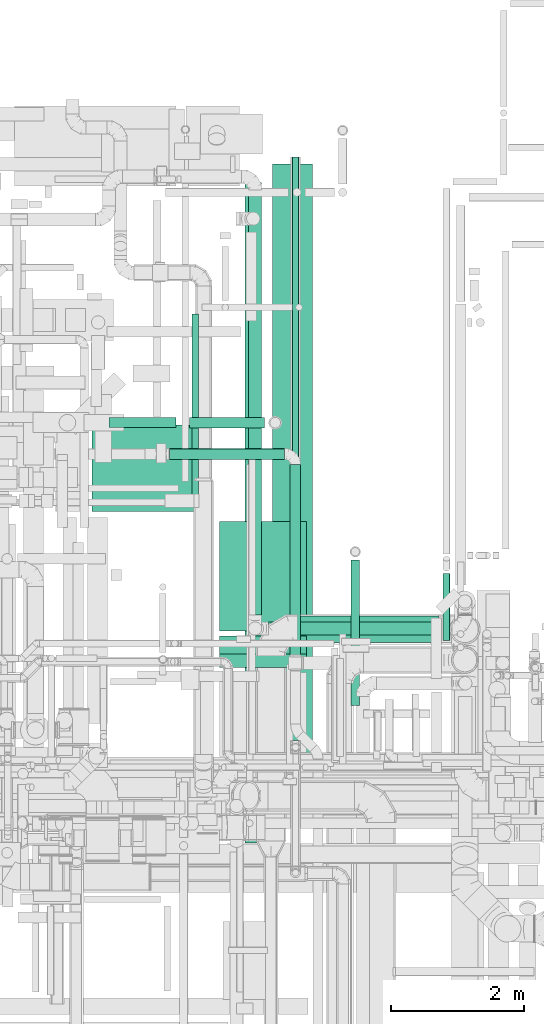
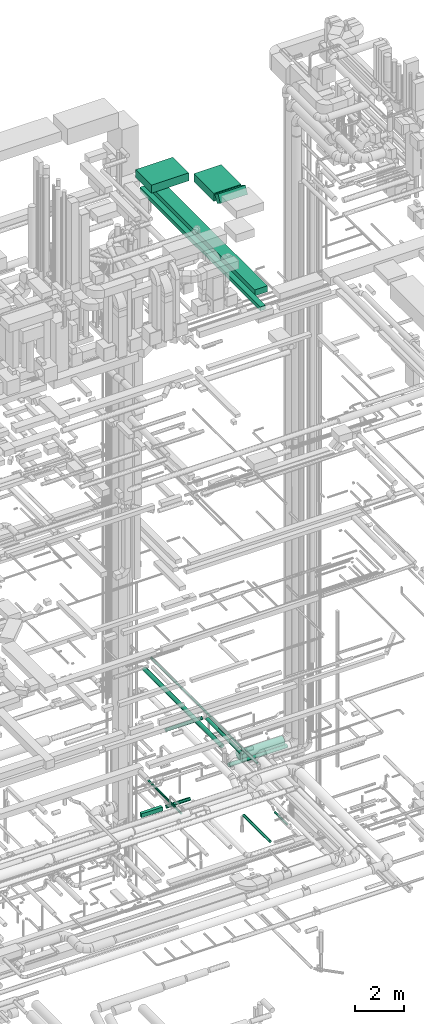
# One storey, part 69 of 337: 16 flow segments.
"""IFC2X3 building model written with IfcOpenShell, lengths in millimetres."""

from ifc_helpers import new_model, entity, si_unit, converted_unit, derived_unit, direction, frame, frame_2d, origin, origin_2d_with_axis, place, context, subcontext, project, spatial, rectangle, circle, extrude, type_object, element, save


model = new_model("IFC2X3")

# Units and contexts
model_context = context("Model", 3, precision=0.01, world=origin(), true_north=direction((6.12303176911189e-17, 1.0)))
body_context = subcontext(model_context, "Body", "Model", "MODEL_VIEW")
ifc_project = project(units=[si_unit("LENGTHUNIT", "METRE", prefix="MILLI"), si_unit("AREAUNIT", "SQUARE_METRE"), si_unit("VOLUMEUNIT", "CUBIC_METRE"), converted_unit("PLANEANGLEUNIT", "DEGREE", entity("IfcRatioMeasure", 0.0174532925199433), si_unit("PLANEANGLEUNIT", "RADIAN"), dimensions=[0, 0, 0, 0, 0, 0, 0]), si_unit("MASSUNIT", "GRAM", prefix="KILO"), derived_unit("MASSDENSITYUNIT", [(si_unit("MASSUNIT", "GRAM", prefix="KILO"), 1), (si_unit("LENGTHUNIT", "METRE"), -3)]), derived_unit("MOMENTOFINERTIAUNIT", [(si_unit("LENGTHUNIT", "METRE"), 4)]), si_unit("TIMEUNIT", "SECOND"), si_unit("FREQUENCYUNIT", "HERTZ"), si_unit("THERMODYNAMICTEMPERATUREUNIT", "DEGREE_CELSIUS"), derived_unit("THERMALTRANSMITTANCEUNIT", [(si_unit("MASSUNIT", "GRAM", prefix="KILO"), 1), (si_unit("THERMODYNAMICTEMPERATUREUNIT", "KELVIN"), -1), (si_unit("TIMEUNIT", "SECOND"), -3)]), derived_unit("VOLUMETRICFLOWRATEUNIT", [(si_unit("LENGTHUNIT", "METRE"), 3), (si_unit("TIMEUNIT", "SECOND"), -1)]), derived_unit("MASSFLOWRATEUNIT", [(si_unit("MASSUNIT", "GRAM", prefix="KILO"), 1), (si_unit("TIMEUNIT", "SECOND"), -1)]), derived_unit("ROTATIONALFREQUENCYUNIT", [(si_unit("TIMEUNIT", "SECOND"), -1)]), si_unit("ELECTRICCURRENTUNIT", "AMPERE"), si_unit("ELECTRICVOLTAGEUNIT", "VOLT"), si_unit("POWERUNIT", "WATT"), si_unit("FORCEUNIT", "NEWTON", prefix="KILO"), si_unit("ILLUMINANCEUNIT", "LUX"), si_unit("LUMINOUSFLUXUNIT", "LUMEN"), si_unit("LUMINOUSINTENSITYUNIT", "CANDELA"), derived_unit("USERDEFINED", [(si_unit("MASSUNIT", "GRAM", prefix="KILO"), -1), (si_unit("LENGTHUNIT", "METRE"), -2), (si_unit("TIMEUNIT", "SECOND"), 3), (si_unit("LUMINOUSFLUXUNIT", "LUMEN"), 1)]), derived_unit("LINEARVELOCITYUNIT", [(si_unit("LENGTHUNIT", "METRE"), 1), (si_unit("TIMEUNIT", "SECOND"), -1)]), si_unit("PRESSUREUNIT", "PASCAL"), derived_unit("USERDEFINED", [(si_unit("LENGTHUNIT", "METRE"), -2), (si_unit("MASSUNIT", "GRAM", prefix="KILO"), 1), (si_unit("TIMEUNIT", "SECOND"), -2)]), derived_unit("LINEARFORCEUNIT", [(si_unit("MASSUNIT", "GRAM", prefix="KILO"), 1), (si_unit("LENGTHUNIT", "METRE"), 1), (si_unit("TIMEUNIT", "SECOND"), -2), (si_unit("LENGTHUNIT", "METRE"), -1)]), derived_unit("PLANARFORCEUNIT", [(si_unit("MASSUNIT", "GRAM", prefix="KILO"), 1), (si_unit("LENGTHUNIT", "METRE"), 1), (si_unit("TIMEUNIT", "SECOND"), -2), (si_unit("LENGTHUNIT", "METRE"), -2)])], contexts=[model_context])

# Site, building, storey
site_placement = place(None, origin())
site = spatial("IfcSite", under=ifc_project, at=site_placement, CompositionType="ELEMENT")
building_placement = place(site_placement, origin())
building = spatial("IfcBuilding", under=site, at=building_placement, CompositionType="ELEMENT")
storey_placement = place(building_placement, origin())
storey = spatial("IfcBuildingStorey", under=building, at=storey_placement, CompositionType="ELEMENT", Elevation=0.0)

# Flow segments
duct_segment_type_1 = type_object("IfcDuctSegmentType", PredefinedType="NOTDEFINED")
flow_segment_1_placement = place(storey_placement, frame((62220.37, 15273.96, -950.0)))
element("IfcFlowSegment", 1, at=flow_segment_1_placement, inside=storey, type_object=duct_segment_type_1, context=body_context, shape_type="SweptSolid", body=[
    extrude(rectangle(XDim=1006.91276425047, YDim=150.000000000001, at=origin_2d_with_axis()), frame((503.46, 75.0, 0.0)), (0.0, 0.0, 1.0), 200.0),
])
flow_segment_2_placement = place(storey_placement, frame((64257.65, 9045.02, 27550.0)))
element("IfcFlowSegment", 2, at=flow_segment_2_placement, inside=storey, type_object=duct_segment_type_1, context=body_context, shape_type="SweptSolid", body=[
    extrude(rectangle(XDim=9908.10000000008, YDim=250.000000000004, at=origin_2d_with_axis()), frame((125.0, 4954.05, 0.0), z_axis=(0.0, 0.0, 1.0), x_axis=(0.0, 1.0, 0.0)), (0.0, 0.0, 1.0), 199.999999999998),
])
flow_segment_3_placement = place(storey_placement, frame((64670.0, 10213.98, 27450.0)))
element("IfcFlowSegment", 3, at=flow_segment_3_placement, inside=storey, type_object=duct_segment_type_1, context=body_context, shape_type="SweptSolid", body=[
    extrude(rectangle(XDim=9020.00000000004, YDim=600.000000000002, at=origin_2d_with_axis()), frame((300.0, 4510.0, 0.0), z_axis=(0.0, 0.0, 1.0), x_axis=(0.0, 1.0, 0.0)), (0.0, 0.0, 1.0), 300.000000000001),
])
duct_segment_type_2 = type_object("IfcDuctSegmentType", PredefinedType="NOTDEFINED")
flow_segment_4_placement = place(storey_placement, frame((63427.28, 15267.36, -931.6)))
element("IfcFlowSegment", 4, at=flow_segment_4_placement, inside=storey, type_object=duct_segment_type_2, context=body_context, shape_type="SweptSolid", body=[
    extrude(circle(Radius=80.0, at=origin_2d_with_axis()), frame((0.0, 81.6, 81.6), z_axis=(1.0, 0.0, 0.0), x_axis=(0.0, -1.0, 0.0)), (0.0, 0.0, 1.0), 1126.40133976584),
])
flow_segment_5_placement = place(storey_placement, frame((65849.84, 11105.22, -964.1)))
element("IfcFlowSegment", 5, at=flow_segment_5_placement, inside=storey, type_object=duct_segment_type_2, context=body_context, shape_type="SweptSolid", body=[
    extrude(circle(Radius=62.5, at=origin_2d_with_axis()), frame((64.1, 0.0, 64.1), z_axis=(0.0, 1.0, 0.0), x_axis=(1.0, 0.0, 0.0)), (0.0, 0.0, 1.0), 2182.57919999999),
])
flow_segment_6_placement = place(storey_placement, frame((67230.68, 12078.54, -1161.6)))
element("IfcFlowSegment", 6, at=flow_segment_6_placement, inside=storey, type_object=duct_segment_type_2, context=body_context, shape_type="SweptSolid", body=[
    extrude(circle(Radius=50.0, at=origin_2d_with_axis()), frame((51.6, 0.0, 51.6), z_axis=(0.0, 1.0, 0.0), x_axis=(1.0, 0.0, 0.0)), (0.0, 0.0, 1.0), 1009.4652237627),
])
flow_segment_7_placement = place(storey_placement, frame((63462.6, 14253.27, -601.6)))
element("IfcFlowSegment", 7, at=flow_segment_7_placement, inside=storey, type_object=duct_segment_type_2, context=body_context, shape_type="SweptSolid", body=[
    extrude(circle(Radius=50.0, at=origin_2d_with_axis()), frame((51.6, 0.0, 51.6), z_axis=(0.0, 1.0, 0.0), x_axis=(1.0, 0.0, 0.0)), (0.0, 0.0, 1.0), 2726.83352),
])
flow_segment_8_placement = place(storey_placement, frame((65048.27, 12048.32, 2848.4)))
element("IfcFlowSegment", 8, at=flow_segment_8_placement, inside=storey, type_object=duct_segment_type_2, context=body_context, shape_type="SweptSolid", body=[
    extrude(circle(Radius=200.0, at=origin_2d_with_axis()), frame((0.0, 201.6, 201.6), z_axis=(1.0, 0.0, 0.0), x_axis=(0.0, 1.0, 0.0)), (0.0, 0.0, 1.0), 2114.94669087573),
])
flow_segment_9_placement = place(storey_placement, frame((64965.15, 10579.14, 3598.4)))
element("IfcFlowSegment", 9, at=flow_segment_9_placement, inside=storey, type_object=duct_segment_type_2, context=body_context, shape_type="SweptSolid", body=[
    extrude(circle(Radius=50.0, at=origin_2d_with_axis()), frame((51.6, 0.0, 51.6), z_axis=(0.0, 1.0, 0.0), x_axis=(1.0, 0.0, 0.0)), (0.0, 0.0, 1.0), 8755.19859995445),
])
flow_segment_10_placement = place(storey_placement, frame((64610.14, 12159.21, 2598.4)))
element("IfcFlowSegment", 10, at=flow_segment_10_placement, inside=storey, type_object=duct_segment_type_2, context=body_context, shape_type="SweptSolid", body=[
    extrude(circle(Radius=100.0, at=origin_2d_with_axis()), frame((0.0, 101.6, 101.6), z_axis=(1.0, 0.0, 0.0), x_axis=(0.0, -1.0, 0.0)), (0.0, 0.0, 1.0), 2753.82994704765),
])
flow_segment_11_placement = place(storey_placement, frame((64932.89, 11864.28, 3298.4)))
element("IfcFlowSegment", 11, at=flow_segment_11_placement, inside=storey, type_object=duct_segment_type_2, context=body_context, shape_type="SweptSolid", body=[
    extrude(circle(Radius=80.0, at=origin_2d_with_axis()), frame((81.6, 0.0, 81.6), z_axis=(0.0, 1.0, 0.0), x_axis=(-1.0, 0.0, 0.0)), (0.0, 0.0, 1.0), 2854.45238542295),
])
flow_segment_12_placement = place(storey_placement, frame((64308.55, 12460.8, 3498.4)))
element("IfcFlowSegment", 12, at=flow_segment_12_placement, inside=storey, type_object=duct_segment_type_2, context=body_context, shape_type="SweptSolid", body=[
    extrude(circle(Radius=100.0, at=origin_2d_with_axis()), frame((101.6, 0.0, 101.6), z_axis=(0.0, 1.0, 0.0), x_axis=(1.0, 0.0, 0.0)), (0.0, 0.0, 1.0), 6380.00000000002),
])
flow_segment_13_placement = place(storey_placement, frame((63127.15, 14797.14, 3298.4)))
element("IfcFlowSegment", 13, at=flow_segment_13_placement, inside=storey, type_object=duct_segment_type_2, context=body_context, shape_type="SweptSolid", body=[
    extrude(circle(Radius=80.0, at=origin_2d_with_axis()), frame((0.0, 81.6, 81.6), z_axis=(1.0, 0.0, 0.0), x_axis=(0.0, 1.0, 0.0)), (0.0, 0.0, 1.0), 1727.34177453729),
])
duct_segment_type_3 = type_object("IfcDuctSegmentType", PredefinedType="NOTDEFINED")
flow_segment_14_placement = place(storey_placement, frame((61963.17, 14014.6, 31250.0)))
element("IfcFlowSegment", 14, at=flow_segment_14_placement, inside=storey, type_object=duct_segment_type_3, context=body_context, shape_type="SweptSolid", body=[
    extrude(rectangle(XDim=1766.81781000004, YDim=1300.0, at=origin_2d_with_axis()), frame((883.41, 650.0, 0.0)), (0.0, 0.0, 1.0), 399.999999999996),
])
flow_segment_15_placement = place(storey_placement, frame((63879.98, 12220.77, 31250.0)))
element("IfcFlowSegment", 15, at=flow_segment_15_placement, inside=storey, type_object=duct_segment_type_3, context=body_context, shape_type="SweptSolid", body=[
    extrude(rectangle(XDim=1643.82869280079, YDim=1300.0, at=origin_2d_with_axis()), frame((650.0, 821.91, 0.0), z_axis=(0.0, 0.0, 1.0), x_axis=(0.0, -1.0, 0.0)), (0.0, 0.0, 1.0), 400.000000000004),
])
flow_segment_16_placement = place(storey_placement, frame((63879.98, 11675.2, 31323.69)))
element("IfcFlowSegment", 16, at=flow_segment_16_placement, inside=storey, type_object=duct_segment_type_3, context=body_context, shape_type="SweptSolid", body=[
    extrude(rectangle(XDim=400.000000000005, YDim=312.435582496168, at=frame_2d((0.0, 0.0), x_axis=(0.0, 1.0))), frame((0.0, 235.29, 251.31), z_axis=(1.0, 0.0, 0.0), x_axis=(0.0, 0.86602541071261, -0.499999988000055)), (0.0, 0.0, 1.0), 1300.0),
])

save(model, "model.ifc")
